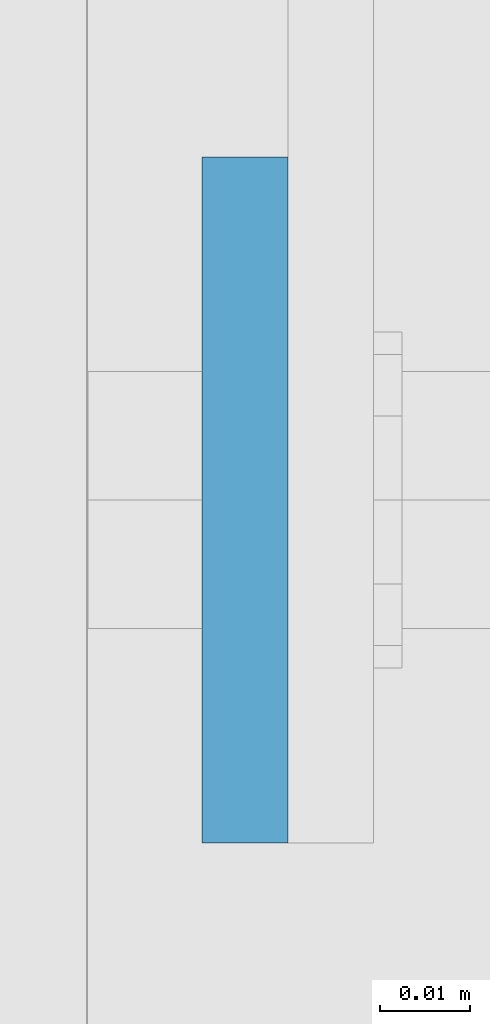
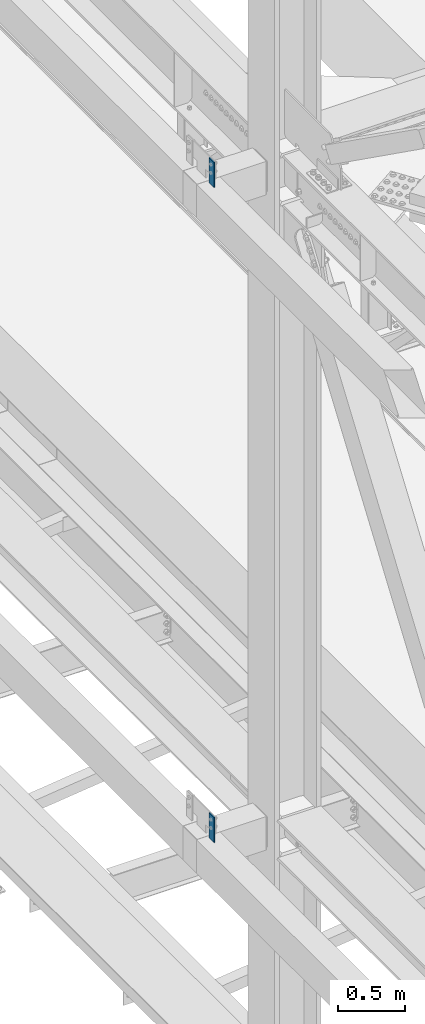
# One storey, part 1524 of 3843: 2 columns, 2 elements without a shape of their own.
"""IFC2X3 building model written with IfcOpenShell, lengths in millimetres."""

from ifc_helpers import new_model, si_unit, frame, origin_with_axes, place, context, subcontext, project, spatial, faceted_brep, material, type_object, element, aggregate, save


model = new_model("IFC2X3")

# Units and contexts
model_context = context("Model", 3, precision=1e-05, world=origin_with_axes())
body_context = subcontext(model_context, "Body", "Model", "MODEL_VIEW")
ifc_project = project(units=[si_unit("LENGTHUNIT", "METRE", prefix="MILLI"), si_unit("AREAUNIT", "SQUARE_METRE"), si_unit("VOLUMEUNIT", "CUBIC_METRE"), si_unit("MASSUNIT", "GRAM", prefix="KILO"), si_unit("TIMEUNIT", "SECOND"), si_unit("PLANEANGLEUNIT", "RADIAN"), si_unit("SOLIDANGLEUNIT", "STERADIAN"), si_unit("THERMODYNAMICTEMPERATUREUNIT", "DEGREE_CELSIUS"), si_unit("LUMINOUSINTENSITYUNIT", "LUMEN")], contexts=[model_context])

# Site, building, storey
site_placement = place(None, origin_with_axes())
site = spatial("IfcSite", under=ifc_project, at=site_placement, CompositionType="ELEMENT")
building_placement = place(site_placement, origin_with_axes())
building = spatial("IfcBuilding", under=site, at=building_placement, Name="Undefined", CompositionType="ELEMENT")
storey_placement = place(building_placement, origin_with_axes())
storey = spatial("IfcBuildingStorey", under=building, at=storey_placement, Name="Undefined", CompositionType="ELEMENT", Elevation=0.0)

# Assembly, column
assembly_1_placement = place(storey_placement, origin_with_axes())
assembly_1 = element("IfcElementAssembly", 1, at=assembly_1_placement, inside=storey, Name="GIRT", AssemblyPlace="NOTDEFINED", PredefinedType="RIGID_FRAME")
ifc_material = material(Name="STEEL/A572-50")
column_type = type_object("IfcColumnType", PredefinedType="NOTDEFINED")
column_1_placement = place(assembly_1_placement, frame((35856.8625, 58750.2, 36404.55), z_axis=(0.0, 1.0, 0.0), x_axis=(0.0, 0.0, 1.0)))
column_1 = element("IfcColumn", 2, at=column_1_placement, type_object=column_type, material=ifc_material, Name="PLATE", context=body_context, shape_type="Brep", body=[
    faceted_brep([(0.0, 4.76250000000073, -38.0999999999985), (0.0, 4.76250000000073, 38.0999999999985), (228.599999999999, 4.76249999999709, 38.1000000000058), (228.599999999999, 4.76249999999709, -38.1000000000058), (0.0, -4.76250000000073, 38.0999999999985), (228.599999999999, -4.76249999999709, 38.1000000000058), (0.0, -4.76250000000073, -38.0999999999985), (228.599999999999, -4.76249999999709, -38.1000000000058)], [[[0, 1, 2, 3]], [[1, 4, 5, 2]], [[4, 6, 7, 5]], [[6, 0, 3, 7]], [[5, 7, 3, 2]], [[6, 4, 1, 0]]]),
])
aggregate(assembly_1, [column_1])

assembly_2_placement = place(storey_placement, origin_with_axes())
assembly_2 = element("IfcElementAssembly", 3, at=assembly_2_placement, inside=storey, Name="GIRT", AssemblyPlace="NOTDEFINED", PredefinedType="RIGID_FRAME")
column_2_placement = place(assembly_2_placement, frame((35856.8625, 58750.2, 42367.2), z_axis=(0.0, 1.0, 0.0), x_axis=(0.0, 0.0, 1.0)))
column_2 = element("IfcColumn", 4, at=column_2_placement, type_object=column_type, material=ifc_material, Name="PLATE", context=body_context, shape_type="Brep", body=[
    faceted_brep([(0.0, 4.76250000000073, -38.0999999999985), (0.0, 4.76250000000073, 38.0999999999985), (228.599999999999, 4.76249999999709, 38.1000000000058), (228.599999999999, 4.76249999999709, -38.1000000000058), (0.0, -4.76250000000073, 38.0999999999985), (228.599999999999, -4.76249999999709, 38.1000000000058), (0.0, -4.76250000000073, -38.0999999999985), (228.599999999999, -4.76249999999709, -38.1000000000058)], [[[0, 1, 2, 3]], [[1, 4, 5, 2]], [[4, 6, 7, 5]], [[6, 0, 3, 7]], [[5, 7, 3, 2]], [[6, 4, 1, 0]]]),
])
aggregate(assembly_2, [column_2])

save(model, "model.ifc")
